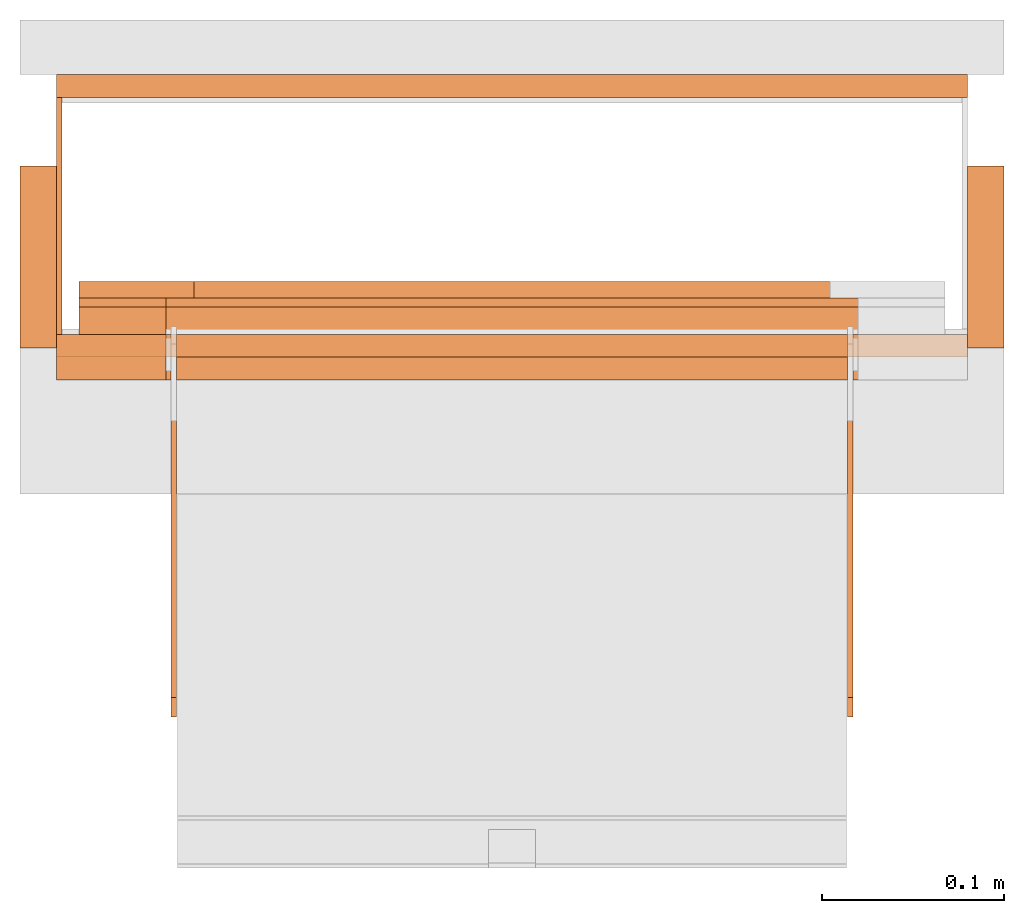
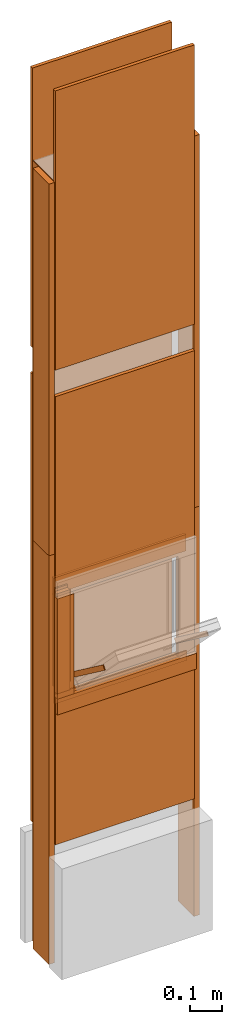
# One storey, part 1 of 3: 20 proxies, 1 opening.
"""IFC2X3 building model written with IfcOpenShell, lengths in metres."""

from ifc_helpers import new_model, entity, si_unit, converted_unit, derived_unit, money_unit, direction, frame, origin_with_axes, origin_2d_with_axis, place, context, subcontext, project, spatial, polyline, rectangle, outline, extrude, faceted_brep, source, transform, mapped, material, type_object, element, save


model = new_model("IFC2X3")

# Units and contexts
model_context = context("Model", 3, precision=1e-05, world=origin_with_axes(), true_north=direction((0.0, 1.0)))
plan_context = context("Plan", 3, precision=1e-05, world=origin_with_axes(), true_north=direction((0.0, 1.0)))
body_context = subcontext(model_context, "Body", "Model", "MODEL_VIEW")
ifc_project = project(units=[si_unit("LENGTHUNIT", "METRE"), si_unit("AREAUNIT", "SQUARE_METRE"), si_unit("VOLUMEUNIT", "CUBIC_METRE"), converted_unit("PLANEANGLEUNIT", "DEGREE", entity("IfcPlaneAngleMeasure", 0.0174532925199), si_unit("PLANEANGLEUNIT", "RADIAN"), dimensions=[0, 0, 0, 0, 0, 0, 0]), si_unit("SOLIDANGLEUNIT", "STERADIAN"), money_unit("CHF"), converted_unit("TIMEUNIT", "Year", entity("IfcTimeMeasure", 31556926.0), si_unit("TIMEUNIT", "SECOND"), dimensions=[0, 0, 1, 0, 0, 0, 0]), si_unit("MASSUNIT", "GRAM", prefix="KILO"), si_unit("THERMODYNAMICTEMPERATUREUNIT", "DEGREE_CELSIUS"), si_unit("LUMINOUSINTENSITYUNIT", "LUMEN"), si_unit("ENERGYUNIT", "JOULE", prefix="MEGA"), derived_unit("THERMALCONDUCTANCEUNIT", [(si_unit("POWERUNIT", "WATT"), 1), (si_unit("LENGTHUNIT", "METRE"), -1), (si_unit("THERMODYNAMICTEMPERATUREUNIT", "KELVIN"), -1)]), derived_unit("SPECIFICHEATCAPACITYUNIT", [(si_unit("ENERGYUNIT", "JOULE"), 1), (si_unit("MASSUNIT", "GRAM", prefix="KILO"), -1), (si_unit("THERMODYNAMICTEMPERATUREUNIT", "KELVIN"), -1)]), derived_unit("MASSDENSITYUNIT", [(si_unit("MASSUNIT", "GRAM", prefix="KILO"), 1), (si_unit("VOLUMEUNIT", "CUBIC_METRE"), -1)])], contexts=[model_context, plan_context])

# Site, building, storey
site_placement = place(None, origin_with_axes())
site = spatial("IfcSite", under=ifc_project, at=site_placement, CompositionType="ELEMENT")
building_placement = place(site_placement, origin_with_axes())
building = spatial("IfcBuilding", under=site, at=building_placement, CompositionType="ELEMENT")
storey_placement = place(building_placement, frame((0.0, 0.0, 2.96), z_axis=(0.0, 0.0, 1.0), x_axis=(1.0, 0.0, 0.0)))
storey = spatial("IfcBuildingStorey", under=building, at=storey_placement, Name="OG01", CompositionType="ELEMENT", Elevation=2.96)

# Proxies
ifc_material_1 = material(Name="Metall, Stahl")
building_element_proxy_type_1 = type_object("IfcBuildingElementProxyType", Name="Metall, Stahl 3", PredefinedType="NOTDEFINED")
proxy_1_placement = place(storey_placement, frame((9.11522436818, -8.09743070606, -0.4), z_axis=(0.0, 0.0, 1.0), x_axis=(0.0, -1.0, 0.0)))
element("IfcBuildingElementProxy", 1, at=proxy_1_placement, inside=storey, type_object=building_element_proxy_type_1, material=ifc_material_1, Name="Wand-005", context=body_context, shape_type="SweptSolid", body=[
    extrude(outline(polyline([(0.0, 0.0), (0.13, 0.0), (0.13, 0.003), (0.0, 0.003), (0.0, 0.0)])), origin_with_axes(), (0.0, 0.0, 1.0), 1.55),
])
proxy_2_placement = place(storey_placement, frame((9.11522436818, -8.09743070606, 1.15), z_axis=(0.0, 0.0, 1.0), x_axis=(0.0, -1.0, 0.0)))
element("IfcBuildingElementProxy", 2, at=proxy_2_placement, inside=storey, type_object=building_element_proxy_type_1, material=ifc_material_1, Name="Wand-005", context=body_context, shape_type="SweptSolid", body=[
    extrude(outline(polyline([(0.0, 0.0), (0.13, 0.0), (0.13, 0.003), (0.0, 0.003), (0.0, 0.0)])), origin_with_axes(), (0.0, 0.0, 1.0), 1.41),
])
ifc_material_2 = material(Name="Holz")
building_element_proxy_type_2 = type_object("IfcBuildingElementProxyType", Name="Holz 15", PredefinedType="NOTDEFINED")
proxy_3_placement = place(storey_placement, frame((9.12772436818, -8.22743070606, 0.61), z_axis=(0.0, 0.0, 1.0), x_axis=(1.0, 0.0, 0.0)))
element("IfcBuildingElementProxy", 3, at=proxy_3_placement, inside=storey, type_object=building_element_proxy_type_2, material=ifc_material_2, Name="Wand-004", context=body_context, shape_type="SweptSolid", body=[
    extrude(outline(polyline([(0.0, 0.0), (0.0475, 0.0), (0.0475, 0.015), (0.0, 0.015), (0.0, 0.0)])), origin_with_axes(), (0.0, 0.0, 1.0), 0.38),
])
proxy_4_placement = place(storey_placement, frame((9.60272436818, -8.21243070606, 0.5625), z_axis=(0.0, 0.0, 1.0), x_axis=(-1.0, 0.0, 0.0)))
element("IfcBuildingElementProxy", 4, at=proxy_4_placement, inside=storey, type_object=building_element_proxy_type_2, material=ifc_material_2, Name="Wand-004", context=body_context, shape_type="SweptSolid", body=[
    extrude(outline(polyline([(0.0, 0.0), (0.475, 0.0), (0.475, 0.015), (0.0, 0.015), (0.0, 0.0)])), origin_with_axes(), (0.0, 0.0, 1.0), 0.0475),
])
building_element_proxy_type_3 = type_object("IfcBuildingElementProxyType", Name="Holz 5", PredefinedType="NOTDEFINED")
proxy_5_placement = place(storey_placement, frame((9.12772436818, -8.21243070606, 0.6), z_axis=(0.0, 0.0, 1.0), x_axis=(1.0, 0.0, 0.0)))
element("IfcBuildingElementProxy", 5, at=proxy_5_placement, inside=storey, type_object=building_element_proxy_type_3, material=ifc_material_2, Name="Wand-004", context=body_context, shape_type="SweptSolid", body=[
    extrude(outline(polyline([(0.0, 0.0), (0.0475, 0.0), (0.0475, 0.005), (0.0, 0.005), (0.0, 0.0)])), origin_with_axes(), (0.0, 0.0, 1.0), 0.4),
])
proxy_6_placement = place(storey_placement, frame((9.60272436818, -8.21243070606, 0.5625), z_axis=(0.0, 0.0, 1.0), x_axis=(-1.0, 0.0, 0.0)))
element("IfcBuildingElementProxy", 6, at=proxy_6_placement, inside=storey, type_object=building_element_proxy_type_3, material=ifc_material_2, Name="Wand-004", context=body_context, shape_type="SweptSolid", body=[
    extrude(outline(polyline([(0.0, -0.005), (0.475, -0.005), (0.475, 0.0), (0.0, 0.0), (0.0, -0.005)])), origin_with_axes(), (0.0, 0.0, 1.0), 0.0375),
])
building_element_proxy_type_4 = type_object("IfcBuildingElementProxyType", Name="Holz 25", PredefinedType="NOTDEFINED")
proxy_7_placement = place(storey_placement, frame((9.11522436818, -8.25243070606, 0.61), z_axis=(0.0, 0.0, 1.0), x_axis=(1.0, 0.0, 0.0)))
element("IfcBuildingElementProxy", 7, at=proxy_7_placement, inside=storey, type_object=building_element_proxy_type_4, material=ifc_material_2, Name="Wand-004", context=body_context, shape_type="SweptSolid", body=[
    extrude(outline(polyline([(0.0, 0.0), (0.06, 0.0), (0.06, 0.025), (0.0, 0.025), (0.0, 0.0)])), origin_with_axes(), (0.0, 0.0, 1.0), 0.38),
])
proxy_8_placement = place(storey_placement, frame((9.61522436818, -8.22743070606, 0.55), z_axis=(0.0, 0.0, 1.0), x_axis=(-1.0, 0.0, 0.0)))
element("IfcBuildingElementProxy", 8, at=proxy_8_placement, inside=storey, type_object=building_element_proxy_type_4, material=ifc_material_2, Name="Wand-004", context=body_context, shape_type="SweptSolid", body=[
    extrude(outline(polyline([(0.0, 0.0), (0.5, 0.0), (0.5, 0.025), (0.0, 0.025), (0.0, 0.0)])), origin_with_axes(), (0.0, 0.0, 1.0), 0.06),
])
building_element_proxy_type_5 = type_object("IfcBuildingElementProxyType", Name="Holz 9", PredefinedType="NOTDEFINED")
proxy_9_placement = place(storey_placement, frame((9.12772436818, -8.20743070606, 0.625), z_axis=(0.0, 0.0, 1.0), x_axis=(1.0, 0.0, 0.0)))
element("IfcBuildingElementProxy", 9, at=proxy_9_placement, inside=storey, type_object=building_element_proxy_type_5, material=ifc_material_2, Name="Wand-004", context=body_context, shape_type="SweptSolid", body=[
    extrude(outline(polyline([(0.0, 0.0), (0.063, 0.0), (0.063, 0.009), (0.0, 0.009), (0.0, 0.0)])), origin_with_axes(), (0.0, 0.0, 1.0), 0.35),
])
proxy_10_placement = place(storey_placement, frame((9.60272436818, -8.20743070606, 0.975), z_axis=(0.0, 0.0, 1.0), x_axis=(-1.0, 0.0, 0.0)))
element("IfcBuildingElementProxy", 10, at=proxy_10_placement, inside=storey, type_object=building_element_proxy_type_5, material=ifc_material_2, Name="Wand-004", context=body_context, shape_type="SweptSolid", body=[
    extrude(outline(polyline([(0.0, -0.009), (0.475, -0.009), (0.475, 0.0), (0.0, 0.0), (0.0, -0.009)])), origin_with_axes(), (0.0, 0.0, 1.0), 0.0625),
])

# Proxy, opening
ifc_material_3 = material(Name="Gipsplatte horizontal")
building_element_proxy_type_6 = type_object("IfcBuildingElementProxyType", Name="Gipsplatte horizontal 13", PredefinedType="NOTDEFINED")
proxy_11_placement = place(storey_placement, frame((9.11522436818, -8.23993070606, 0.05), z_axis=(0.0, 0.0, 1.0), x_axis=(1.0, 0.0, 0.0)))
proxy_11 = element("IfcBuildingElementProxy", 11, at=proxy_11_placement, inside=storey, type_object=building_element_proxy_type_6, material=ifc_material_3, Name="Wand-004", context=body_context, shape_type="SweptSolid", body=[
    extrude(outline(polyline([(0.0, 0.0), (0.5, 0.0), (0.5, 0.0125), (0.0, 0.0125), (0.0, 0.0)])), origin_with_axes(), (0.0, 0.0, 1.0), 1.7),
])
opening_placement = place(proxy_11_placement, frame((-9.11522436818, 8.23993070606, -3.01), z_axis=(0.0, 0.0, 1.0), x_axis=(1.0, 0.0, 0.0)))
element("IfcOpeningElement", 12, at=opening_placement, cuts=proxy_11, Name="034", context=body_context, shape_type="SweptSolid", body=[
    extrude(rectangle(XDim=0.38, YDim=0.38, at=origin_2d_with_axis()), frame((9.36522436818, -8.25243070606, 3.76), z_axis=(0.0, -1.0, 0.0), x_axis=(1.0, 0.0, 0.0)), (0.0, 0.0, -1.0), 0.0375),
])

# Proxies
proxy_12_placement = place(storey_placement, frame((9.11522436818, -8.08493070606, 0.05), z_axis=(0.0, 0.0, 1.0), x_axis=(1.0, 0.0, 0.0)))
element("IfcBuildingElementProxy", 13, at=proxy_12_placement, inside=storey, type_object=building_element_proxy_type_6, material=ifc_material_3, Name="Wand-004", context=body_context, shape_type="SweptSolid", body=[
    extrude(outline(polyline([(0.0, -0.0125), (0.5, -0.0125), (0.5, 0.0), (0.0, 0.0), (0.0, -0.0125)])), origin_with_axes(), (0.0, 0.0, 1.0), 1.7),
])
proxy_13_placement = place(storey_placement, frame((9.11522436818, -8.23993070606, 1.85), z_axis=(0.0, 0.0, 1.0), x_axis=(1.0, 0.0, 0.0)))
element("IfcBuildingElementProxy", 14, at=proxy_13_placement, inside=storey, type_object=building_element_proxy_type_6, material=ifc_material_3, Name="Wand-004", context=body_context, shape_type="SweptSolid", body=[
    extrude(outline(polyline([(0.0, 0.0), (0.5, 0.0), (0.5, 0.0125), (0.0, 0.0125), (0.0, 0.0)])), origin_with_axes(), (0.0, 0.0, 1.0), 1.06),
])
proxy_14_placement = place(storey_placement, frame((9.11522436818, -8.08493070606, 1.85), z_axis=(0.0, 0.0, 1.0), x_axis=(1.0, 0.0, 0.0)))
element("IfcBuildingElementProxy", 15, at=proxy_14_placement, inside=storey, type_object=building_element_proxy_type_6, material=ifc_material_3, Name="Wand-004", context=body_context, shape_type="SweptSolid", body=[
    extrude(outline(polyline([(0.0, -0.0125), (0.5, -0.0125), (0.5, 0.0), (0.0, 0.0), (0.0, -0.0125)])), origin_with_axes(), (0.0, 0.0, 1.0), 1.06),
])
building_element_proxy_type_7 = type_object("IfcBuildingElementProxyType", Name="Holz 20", PredefinedType="NOTDEFINED")
proxy_15_placement = place(storey_placement, frame((9.09522436818, -8.13493070606, -0.4), z_axis=(0.0, 0.0, 1.0), x_axis=(0.0, -1.0, 0.0)))
element("IfcBuildingElementProxy", 16, at=proxy_15_placement, inside=storey, type_object=building_element_proxy_type_7, material=ifc_material_2, Name="Wand-004", context=body_context, shape_type="SweptSolid", body=[
    extrude(outline(polyline([(0.0, 0.0), (0.1, 0.0), (0.1, 0.02), (0.0, 0.02), (0.0, 0.0)])), origin_with_axes(), (0.0, 0.0, 1.0), 1.55),
])
proxy_16_placement = place(storey_placement, frame((9.63522436818, -8.13493070606, -0.4), z_axis=(0.0, 0.0, 1.0), x_axis=(0.0, -1.0, 0.0)))
element("IfcBuildingElementProxy", 17, at=proxy_16_placement, inside=storey, type_object=building_element_proxy_type_7, material=ifc_material_2, Name="Wand-003", context=body_context, shape_type="SweptSolid", body=[
    extrude(outline(polyline([(0.0, -0.02), (0.1, -0.02), (0.1, 0.0), (0.0, 0.0), (0.0, -0.02)])), origin_with_axes(), (0.0, 0.0, 1.0), 1.55),
])
proxy_17_placement = place(storey_placement, frame((9.09522436818, -8.13493070606, 1.15), z_axis=(0.0, 0.0, 1.0), x_axis=(0.0, -1.0, 0.0)))
element("IfcBuildingElementProxy", 18, at=proxy_17_placement, inside=storey, type_object=building_element_proxy_type_7, material=ifc_material_2, Name="Wand-004", context=body_context, shape_type="SweptSolid", body=[
    extrude(outline(polyline([(0.0, 0.0), (0.1, 0.0), (0.1, 0.02), (0.0, 0.02), (0.0, 0.0)])), origin_with_axes(), (0.0, 0.0, 1.0), 1.41),
])
proxy_18_placement = place(storey_placement, frame((9.63522436818, -8.13493070606, 1.15), z_axis=(0.0, 0.0, 1.0), x_axis=(0.0, -1.0, 0.0)))
element("IfcBuildingElementProxy", 19, at=proxy_18_placement, inside=storey, type_object=building_element_proxy_type_7, material=ifc_material_2, Name="Wand-003", context=body_context, shape_type="SweptSolid", body=[
    extrude(outline(polyline([(0.0, -0.02), (0.1, -0.02), (0.1, 0.0), (0.0, 0.0), (0.0, -0.02)])), origin_with_axes(), (0.0, 0.0, 1.0), 1.41),
])
ifc_material_4 = material(Name="Metall, Aluminium")
building_element_proxy_type_8 = type_object("IfcBuildingElementProxyType", Name="Metall, Aluminium", PredefinedType="NOTDEFINED")
shared_shape = source(origin_with_axes(), body_context, "Body", "Brep", [
    faceted_brep([(16.1152851057, -3.58730556817, 0.89), (16.1152851057, -3.59030556817, 0.89), (16.1152851057, -3.59030556817, 1.14), (16.1152851057, -3.58730556817, 1.14), (16.1332851057, -3.59030556817, 0.89), (16.1332851057, -3.58730556817, 0.89), (16.1332851057, -3.59030556817, 1.14), (16.1332851057, -3.58730556817, 1.14)], [[[0, 1, 2, 3]], [[4, 1, 0, 5]], [[1, 4, 6, 2]], [[2, 6, 7, 3]], [[0, 3, 7, 5]], [[4, 5, 7, 6]]]),
])
for number, where, z_axis, x_axis, name in (
    (20, (12.7685299364, 2.09768488745, 13.081222354), (0.0, -0.80277012101, 0.596288632135), (0.0, -0.596288632135, -0.80277012101), "Wand-004"),
    (21, (13.1395299364, 2.09768488745, 13.081222354), (0.0, -0.80277012101, 0.596288632135), (0.0, -0.596288632135, -0.80277012101), "Wand-004"),
):
    element("IfcBuildingElementProxy", number, at=place(storey_placement, frame(where, z_axis=z_axis, x_axis=x_axis)), inside=storey, type_object=building_element_proxy_type_8, material=ifc_material_4, Name=name, context=body_context, shape_type="MappedRepresentation", body=[
        mapped(shared_shape, transform((0.0, 0.0, 0.0))),
    ])

save(model, "model.ifc")
